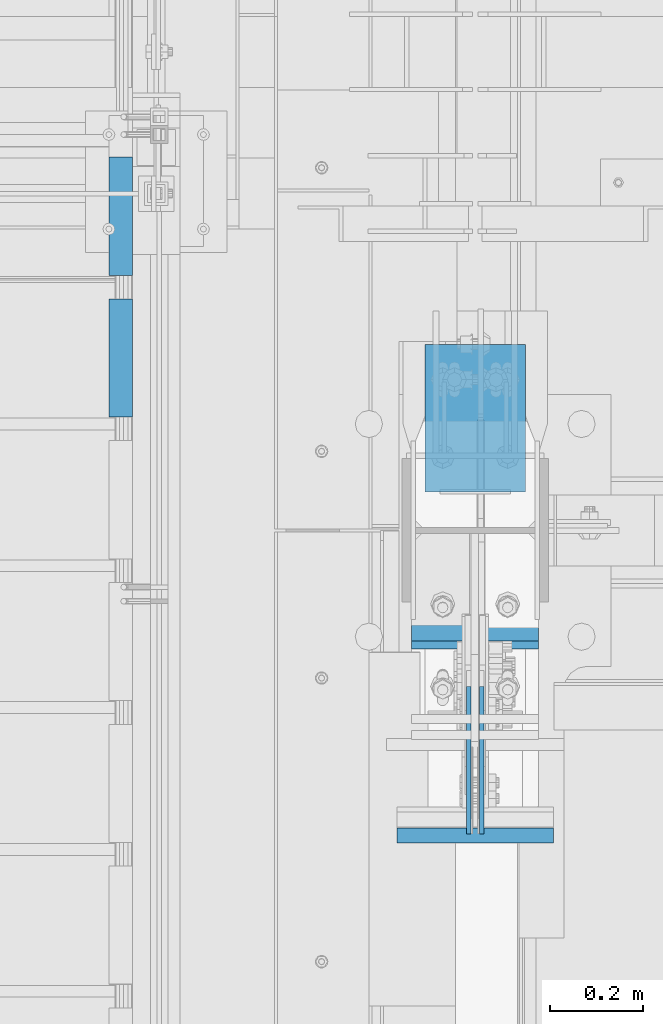
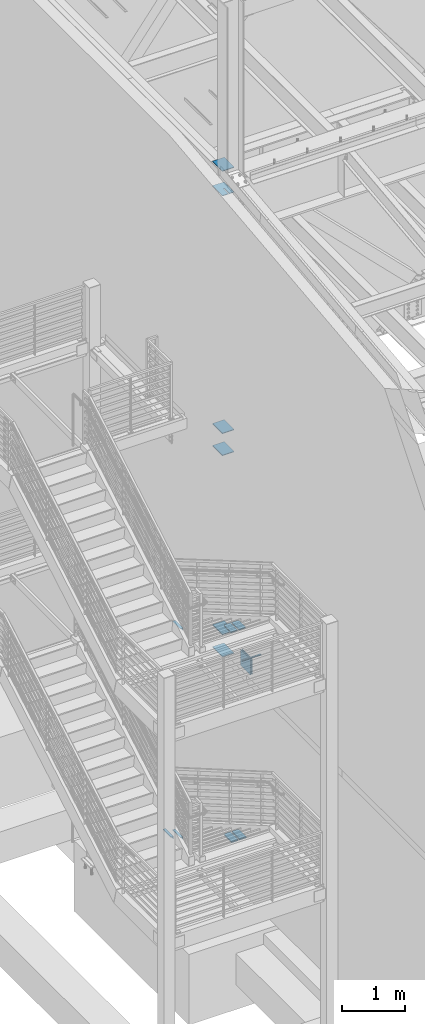
# One storey, part 871 of 1179: 16 beams, 10 elements without a shape of their own.
"""IFC2X3 building model written with IfcOpenShell, lengths in millimetres."""

from ifc_helpers import new_model, si_unit, frame, origin_with_axes, place, context, subcontext, project, spatial, faceted_brep, material, type_object, element, aggregate, save


model = new_model("IFC2X3")

# Units and contexts
model_context = context("Model", 3, precision=1e-05, world=origin_with_axes())
body_context = subcontext(model_context, "Body", "Model", "MODEL_VIEW")
ifc_project = project(units=[si_unit("LENGTHUNIT", "METRE", prefix="MILLI"), si_unit("AREAUNIT", "SQUARE_METRE"), si_unit("VOLUMEUNIT", "CUBIC_METRE"), si_unit("MASSUNIT", "GRAM", prefix="KILO"), si_unit("TIMEUNIT", "SECOND"), si_unit("PLANEANGLEUNIT", "RADIAN"), si_unit("SOLIDANGLEUNIT", "STERADIAN"), si_unit("THERMODYNAMICTEMPERATUREUNIT", "DEGREE_CELSIUS"), si_unit("LUMINOUSINTENSITYUNIT", "LUMEN")], contexts=[model_context])

# Site, building, storey
site_placement = place(None, origin_with_axes())
site = spatial("IfcSite", under=ifc_project, at=site_placement, CompositionType="ELEMENT")
building_placement = place(site_placement, origin_with_axes())
building = spatial("IfcBuilding", under=site, at=building_placement, Name="Undefined", CompositionType="ELEMENT")
storey_placement = place(building_placement, origin_with_axes())
storey = spatial("IfcBuildingStorey", under=building, at=storey_placement, Name="Undefined", CompositionType="ELEMENT", Elevation=0.0)

# Assembly, beam
assembly_1_placement = place(storey_placement, origin_with_axes())
assembly_1 = element("IfcElementAssembly", 1, at=assembly_1_placement, inside=storey, Name="STRINGER", AssemblyPlace="NOTDEFINED", PredefinedType="RIGID_FRAME")
ifc_material_1 = material(Name="STEEL/A36")
beam_type_1 = type_object("IfcBeamType", Name="L2X2X3/16", PredefinedType="NOTDEFINED")
beam_1_placement = place(assembly_1_placement, frame((-330.199999997209, 34889.1356222336, 4333.87499890225), z_axis=(-1.0, 0.0, 0.0), x_axis=(0.0, -1.0, 0.0)))
beam_1 = element("IfcBeam", 2, at=beam_1_placement, type_object=beam_type_1, material=ifc_material_1, Name="ANGLE", ObjectType="L2X2X3/16", context=body_context, shape_type="Brep", body=[
    faceted_brep([(0.0, 25.3999999999996, -25.4000000000015), (0.0, 25.3999999999996, 25.4000000000015), (254.0, 25.3999999999996, 25.4000000000001), (254.0, 25.3999999999996, -25.4000000000001), (0.0, 20.6374999999998, 25.4000000000015), (254.0, 20.6374999999998, 25.4000000000001), (0.0, 20.6374999999998, -20.6374999999971), (254.0, 20.6374999999998, -20.6374999999998), (0.0, -25.3999999999996, -20.6374999999971), (254.0, -25.3999999999996, -20.6374999999998), (0.0, -25.3999999999996, -25.4000000000015), (254.0, -25.3999999999996, -25.4000000000001)], [[[0, 1, 2, 3]], [[1, 4, 5, 2]], [[4, 6, 7, 5]], [[6, 8, 9, 7]], [[8, 10, 11, 9]], [[10, 0, 3, 11]], [[5, 7, 9, 11, 3, 2]], [[10, 8, 6, 4, 1, 0]]]),
])
aggregate(assembly_1, [beam_1])

# Assembly, beams
assembly_2_placement = place(storey_placement, origin_with_axes())
assembly_2 = element("IfcElementAssembly", 3, at=assembly_2_placement, inside=storey, Name="STRINGER", AssemblyPlace="NOTDEFINED", PredefinedType="RIGID_FRAME")
beam_2_placement = place(assembly_2_placement, frame((-330.200000005212, 34889.0824003931, 273.5839774682), z_axis=(-1.0, 0.0, 0.0), x_axis=(0.0, -1.0, 0.0)))
beam_2 = element("IfcBeam", 4, at=beam_2_placement, type_object=beam_type_1, material=ifc_material_1, Name="ANGLE", ObjectType="L2X2X3/16", context=body_context, shape_type="Brep", body=[
    faceted_brep([(0.0, 25.3999999999996, -25.4000000000015), (0.0, 25.3999999999996, 25.4000000000015), (254.0, 25.3999999999996, 25.4000000000001), (254.0, 25.3999999999996, -25.4000000000001), (0.0, 20.6374999999998, 25.4000000000015), (254.0, 20.6374999999998, 25.4000000000001), (0.0, 20.6374999999998, -20.6374999999971), (254.0, 20.6374999999998, -20.6374999999998), (0.0, -25.3999999999996, -20.6374999999971), (254.0, -25.3999999999996, -20.6374999999998), (0.0, -25.3999999999996, -25.4000000000015), (254.0, -25.3999999999996, -25.4000000000001)], [[[0, 1, 2, 3]], [[1, 4, 5, 2]], [[4, 6, 7, 5]], [[6, 8, 9, 7]], [[8, 10, 11, 9]], [[10, 0, 3, 11]], [[5, 7, 9, 11, 3, 2]], [[10, 8, 6, 4, 1, 0]]]),
])
beam_3_placement = place(assembly_2_placement, frame((-330.200000005171, 35193.8825541272, 97.102083331058), z_axis=(-1.0, 0.0, 0.0), x_axis=(0.0, -1.0, 0.0)))
beam_3 = element("IfcBeam", 5, at=beam_3_placement, type_object=beam_type_1, material=ifc_material_1, Name="ANGLE", ObjectType="L2X2X3/16", context=body_context, shape_type="Brep", body=[
    faceted_brep([(0.0, 25.3999999999996, -25.4000000000015), (0.0, 25.3999999999996, 25.4000000000015), (254.0, 25.3999999999996, 25.4000000000001), (254.0, 25.3999999999996, -25.4000000000001), (0.0, 20.6374999999998, 25.4000000000015), (254.0, 20.6374999999998, 25.4000000000001), (0.0, 20.6374999999998, -20.6374999999971), (254.0, 20.6374999999998, -20.6374999999998), (0.0, -25.3999999999996, -20.6374999999971), (254.0, -25.3999999999996, -20.6374999999998), (0.0, -25.3999999999996, -25.4000000000015), (254.0, -25.3999999999996, -25.4000000000001)], [[[0, 1, 2, 3]], [[1, 4, 5, 2]], [[4, 6, 7, 5]], [[6, 8, 9, 7]], [[8, 10, 11, 9]], [[10, 0, 3, 11]], [[5, 7, 9, 11, 3, 2]], [[10, 8, 6, 4, 1, 0]]]),
])
aggregate(assembly_2, [beam_2, beam_3])

# Assembly, beam
assembly_3_placement = place(storey_placement, origin_with_axes())
assembly_3 = element("IfcElementAssembly", 6, at=assembly_3_placement, inside=storey, Name="BEAM", AssemblyPlace="NOTDEFINED", PredefinedType="RIGID_FRAME")
ifc_material_2 = material(Name="STEEL/A572-GR.50")
beam_type_2 = type_object("IfcBeamType", PredefinedType="NOTDEFINED")
beam_4_placement = place(assembly_3_placement, frame((431.800036620873, 33719.866998869, 4077.8905), z_axis=(-1.0, 0.0, 0.0), x_axis=(0.0, 1.0, 0.0)))
beam_4 = element("IfcBeam", 7, at=beam_4_placement, type_object=beam_type_2, material=ifc_material_2, Name="PLATE", context=body_context, shape_type="Brep", body=[
    faceted_brep([(0.0, 4.76249999999982, -168.275000000001), (0.0, 4.76250000000073, 168.275), (31.75, 4.76249999999982, 168.275000000001), (31.75, 4.76249999999982, -168.275000000001), (0.0, -4.76250000000073, 168.275), (31.75, -4.76249999999982, 168.275000000001), (0.0, -4.76249999999982, -168.275000000001), (31.75, -4.76249999999982, -168.275000000001)], [[[0, 1, 2, 3]], [[1, 4, 5, 2]], [[4, 6, 7, 5]], [[6, 0, 3, 7]], [[5, 7, 3, 2]], [[6, 4, 1, 0]]]),
])
aggregate(assembly_3, [beam_4])

assembly_4_placement = place(storey_placement, origin_with_axes())
assembly_4 = element("IfcElementAssembly", 8, at=assembly_4_placement, inside=storey, Name="PLATE", AssemblyPlace="NOTDEFINED", PredefinedType="RIGID_FRAME")
beam_type_3 = type_object("IfcBeamType", PredefinedType="NOTDEFINED")
beam_5_placement = place(assembly_4_placement, frame((505.619000000002, 34153.8677008004, 4353.49928057188), z_axis=(1.0, 0.0, 0.0), x_axis=(0.0, 1.0, 0.0)))
beam_5 = element("IfcBeam", 9, at=beam_5_placement, type_object=beam_type_3, material=ifc_material_2, Name="PLATE", context=body_context, shape_type="Brep", body=[
    faceted_brep([(231.382299186545, -9.52499999999964, 40.480999976727), (231.382299199606, 9.52499999999964, 40.480999976727), (209.157299199604, 9.52499999999964, 62.7065000000002), (209.157299199604, -9.52499999999964, 62.7065000000002), (6.18456397205591e-11, -9.52499999999964, -62.7065000000084), (0.0, -9.52499999999964, 62.7065000000002), (0.0, 9.52499999999964, 62.7065000000002), (6.18456397205591e-11, 9.52499999999964, -62.7065000000084), (231.382299199602, 9.52499999999964, -62.7065000000002), (231.382299199602, -9.52499999999964, -62.7065000000002)], [[[0, 1, 2, 3]], [[4, 5, 6, 7]], [[4, 7, 8, 9]], [[5, 4, 9, 0, 3]], [[6, 5, 3, 2]], [[8, 7, 6, 2, 1]], [[9, 8, 1, 0]]]),
])
aggregate(assembly_4, [beam_5])

assembly_5_placement = place(storey_placement, origin_with_axes())
assembly_5 = element("IfcElementAssembly", 10, at=assembly_5_placement, inside=storey, Name="PLATE", AssemblyPlace="NOTDEFINED", PredefinedType="RIGID_FRAME")
beam_6_placement = place(assembly_5_placement, frame((357.981000000002, 34153.8677008004, 4353.49928057188), z_axis=(-1.0, 0.0, 0.0), x_axis=(0.0, 1.0, 0.0)))
beam_6 = element("IfcBeam", 11, at=beam_6_placement, type_object=beam_type_3, material=ifc_material_2, Name="PLATE", context=body_context, shape_type="Brep", body=[
    faceted_brep([(231.382299186545, -9.52499999999964, 40.480999976727), (231.382299199606, 9.52499999999964, 40.480999976727), (209.157299199604, 9.52499999999964, 62.7065000000002), (209.157299199604, -9.52499999999964, 62.7065000000002), (6.18456397205591e-11, -9.52499999999964, -62.7065000000084), (0.0, -9.52499999999964, 62.7065000000002), (0.0, 9.52499999999964, 62.7065000000002), (6.18456397205591e-11, 9.52499999999964, -62.7065000000084), (231.382299199602, 9.52499999999964, -62.7065000000002), (231.382299199602, -9.52499999999964, -62.7065000000002)], [[[0, 1, 2, 3]], [[4, 5, 6, 7]], [[4, 7, 8, 9]], [[5, 4, 9, 0, 3]], [[6, 5, 3, 2]], [[8, 7, 6, 2, 1]], [[9, 8, 1, 0]]]),
])
aggregate(assembly_5, [beam_6])

# Assembly, beams
assembly_6_placement = place(storey_placement, origin_with_axes())
assembly_6 = element("IfcElementAssembly", 12, at=assembly_6_placement, inside=storey, Name="COLUMN", AssemblyPlace="NOTDEFINED", PredefinedType="RIGID_FRAME")
beam_type_4 = type_object("IfcBeamType", PredefinedType="NOTDEFINED")
beam_7_placement = place(assembly_6_placement, frame((431.799999999996, 34474.1499999871, 12646.024999977), z_axis=(1.0, 0.0, 0.0), x_axis=(0.0, 1.0, 0.0)))
beam_7 = element("IfcBeam", 13, at=beam_7_placement, type_object=beam_type_4, material=ifc_material_2, Name="PLATE", context=body_context, shape_type="Brep", body=[
    faceted_brep([(0.0, -6.35000000000036, 19.8437500550863), (0.0, 6.35000000000036, 19.8437500550863), (150.812499998719, 6.35000000000036, 19.8437500546802), (150.812499998719, -6.35000000000036, 19.8437500546802), (153.850049742483, 6.35000000000036, 19.2395438442423), (153.850049742483, -6.35000000000036, 19.2395438442423), (156.425160073413, 6.35000000000036, 17.5189101313016), (156.425160073413, -6.35000000000036, 17.5189101313016), (158.145793787233, 6.35000000000036, 14.9437998009562), (158.145793787233, -6.35000000000036, 14.9437998009562), (150.812499998683, -6.35000000000036, 3.96875005468019), (150.812499998683, 6.35000000000036, 3.96875005468019), (0.0, 6.35000000000036, 3.96875005508628), (0.0, -6.35000000000036, 3.96875005508628), (153.850049743713, -6.35000000000036, 4.57295626562569), (153.850049743713, 6.35000000000036, 4.57295626562569), (156.42516007532, -6.35000000000036, 6.29358997996519), (156.42516007532, 6.35000000000036, 6.29358997996519), (158.14579378879, -6.35000000000036, 8.8687003121604), (158.14579378879, 6.35000000000036, 8.8687003121604), (158.749999998705, -6.35000000000036, 11.9062500573978), (158.749999998705, 6.35000000000036, 11.9062500573978), (0.0, 6.35000000000036, 107.949999999997), (0.0, -6.35000000000036, 107.949999999997), (317.5, -6.35000000000036, 107.949999999997), (317.5, 6.35000000000036, 107.949999999997), (317.5, -6.35000000000036, -107.949999999997), (317.5, 6.35000000000036, -107.949999999997), (0.0, -6.35000000000036, -107.949999999997), (0.0, 6.35000000000036, -107.949999999997)], [[[0, 1, 2, 3]], [[3, 2, 4, 5]], [[5, 4, 6, 7]], [[7, 6, 8, 9]], [[10, 11, 12, 13]], [[14, 15, 11, 10]], [[16, 17, 15, 14]], [[18, 19, 17, 16]], [[20, 21, 19, 18]], [[9, 8, 21, 20]], [[22, 23, 24, 25]], [[24, 26, 27, 25]], [[28, 29, 27, 26]], [[29, 28, 13, 12]], [[6, 4, 2, 1, 22, 25, 27, 29, 12, 11, 15, 17, 19, 21, 8]], [[23, 22, 1, 0]], [[16, 14, 10, 13, 28, 26, 24, 23, 0, 3, 5, 7, 9, 20, 18]]]),
])
beam_8_placement = place(assembly_6_placement, frame((431.800000009011, 34474.15, 13125.4499999541), z_axis=(1.0, 0.0, 0.0), x_axis=(0.0, 1.0, 0.0)))
beam_8 = element("IfcBeam", 14, at=beam_8_placement, type_object=beam_type_4, material=ifc_material_2, Name="PLATE", context=body_context, shape_type="Brep", body=[
    faceted_brep([(0.0, 6.35000000000036, -107.949999999997), (0.0, 6.35000000000036, 107.949999999997), (317.5, 6.35000000000036, 107.949999999997), (317.5, 6.35000000000036, -107.949999999997), (0.0, -6.35000000000036, 107.949999999997), (317.5, -6.35000000000036, 107.949999999997), (0.0, -6.35000000000036, -107.949999999997), (317.5, -6.35000000000036, -107.949999999997)], [[[0, 1, 2, 3]], [[1, 4, 5, 2]], [[4, 6, 7, 5]], [[6, 0, 3, 7]], [[5, 7, 3, 2]], [[6, 4, 1, 0]]]),
])
beam_9_placement = place(assembly_6_placement, frame((431.799999999996, 34474.15, 7591.425), z_axis=(1.0, 0.0, 0.0), x_axis=(0.0, 1.0, 0.0)))
beam_9 = element("IfcBeam", 15, at=beam_9_placement, type_object=beam_type_4, material=ifc_material_2, Name="PLATE", context=body_context, shape_type="Brep", body=[
    faceted_brep([(0.0, 6.35000000000036, -107.949999999997), (0.0, 6.35000000000036, 107.949999999997), (317.5, 6.35000000000036, 107.949999999997), (317.5, 6.35000000000036, -107.949999999997), (0.0, -6.35000000000036, 107.949999999997), (317.5, -6.35000000000036, 107.949999999997), (0.0, -6.35000000000036, -107.949999999997), (317.5, -6.35000000000036, -107.949999999997)], [[[0, 1, 2, 3]], [[1, 4, 5, 2]], [[4, 6, 7, 5]], [[6, 0, 3, 7]], [[5, 7, 3, 2]], [[6, 4, 1, 0]]]),
])
beam_10_placement = place(assembly_6_placement, frame((431.799999999996, 34474.15, 8020.05), z_axis=(1.0, 0.0, 0.0), x_axis=(0.0, 1.0, 0.0)))
beam_10 = element("IfcBeam", 16, at=beam_10_placement, type_object=beam_type_4, material=ifc_material_2, Name="PLATE", context=body_context, shape_type="Brep", body=[
    faceted_brep([(0.0, 6.35000000000036, -107.949999999997), (0.0, 6.35000000000036, 107.949999999997), (317.5, 6.35000000000036, 107.949999999997), (317.5, 6.35000000000036, -107.949999999997), (0.0, -6.35000000000036, 107.949999999997), (317.5, -6.35000000000036, 107.949999999997), (0.0, -6.35000000000036, -107.949999999997), (317.5, -6.35000000000036, -107.949999999997)], [[[0, 1, 2, 3]], [[1, 4, 5, 2]], [[4, 6, 7, 5]], [[6, 0, 3, 7]], [[5, 7, 3, 2]], [[6, 4, 1, 0]]]),
])
beam_11_placement = place(assembly_6_placement, frame((431.799999999999, 34474.15, 3676.65), z_axis=(1.0, 0.0, 0.0), x_axis=(0.0, 1.0, 0.0)))
beam_11 = element("IfcBeam", 17, at=beam_11_placement, type_object=beam_type_4, material=ifc_material_2, Name="PLATE", context=body_context, shape_type="Brep", body=[
    faceted_brep([(0.0, 6.35000000000036, -107.949999999997), (0.0, 6.35000000000036, 107.949999999997), (317.5, 6.35000000000036, 107.949999999997), (317.5, 6.35000000000036, -107.949999999997), (0.0, -6.35000000000036, 107.949999999997), (317.5, -6.35000000000036, 107.949999999997), (0.0, -6.35000000000036, -107.949999999997), (317.5, -6.35000000000036, -107.949999999997)], [[[0, 1, 2, 3]], [[1, 4, 5, 2]], [[4, 6, 7, 5]], [[6, 0, 3, 7]], [[5, 7, 3, 2]], [[6, 4, 1, 0]]]),
])
beam_12_placement = place(assembly_6_placement, frame((431.799999999999, 34474.15, 4108.45), z_axis=(1.0, 0.0, 0.0), x_axis=(0.0, 1.0, 0.0)))
beam_12 = element("IfcBeam", 18, at=beam_12_placement, type_object=beam_type_4, material=ifc_material_2, Name="PLATE", context=body_context, shape_type="Brep", body=[
    faceted_brep([(0.0, 6.35000000000036, -107.949999999997), (0.0, 6.35000000000036, 107.949999999997), (317.5, 6.35000000000036, 107.949999999997), (317.5, 6.35000000000036, -107.949999999997), (0.0, -6.35000000000036, 107.949999999997), (317.5, -6.35000000000036, 107.949999999997), (0.0, -6.35000000000036, -107.949999999997), (317.5, -6.35000000000036, -107.949999999997)], [[[0, 1, 2, 3]], [[1, 4, 5, 2]], [[4, 6, 7, 5]], [[6, 0, 3, 7]], [[5, 7, 3, 2]], [[6, 4, 1, 0]]]),
])
aggregate(assembly_6, [beam_7, beam_8, beam_9, beam_10, beam_11, beam_12])

# Assembly, beam
assembly_7_placement = place(storey_placement, origin_with_axes())
assembly_7 = element("IfcElementAssembly", 19, at=assembly_7_placement, inside=storey, Name="PLATE", AssemblyPlace="NOTDEFINED", PredefinedType="RIGID_FRAME")
beam_type_5 = type_object("IfcBeamType", PredefinedType="NOTDEFINED")
beam_13_placement = place(assembly_7_placement, frame((356.393499999997, 34136.630498769, 285.099398203347), z_axis=(-1.0, 0.0, 0.0), x_axis=(0.0, 1.0, 0.0)))
beam_13 = element("IfcBeam", 20, at=beam_13_placement, type_object=beam_type_5, material=ifc_material_2, Name="PLATE", context=body_context, shape_type="Brep", body=[
    faceted_brep([(248.619501230954, 12.7, 38.894), (226.394501230956, 12.7, 61.119), (226.394501230956, -12.7, 61.119), (248.619501230954, -12.7, 38.894), (248.619501230954, 12.7, -61.119), (0.0, 12.7, -61.1189999999988), (0.0, 12.7, 61.1189999999988), (0.0, -12.7, 61.1189999999988), (0.0, -12.7, -61.1189999999988), (248.619501230954, -12.7, -61.119)], [[[0, 1, 2, 3]], [[4, 5, 6, 1, 0]], [[6, 7, 2, 1]], [[7, 8, 9, 3, 2]], [[8, 5, 4, 9]], [[9, 4, 0, 3]], [[8, 7, 6, 5]]]),
])
aggregate(assembly_7, [beam_13])

assembly_8_placement = place(storey_placement, origin_with_axes())
assembly_8 = element("IfcElementAssembly", 21, at=assembly_8_placement, inside=storey, Name="PLATE", AssemblyPlace="NOTDEFINED", PredefinedType="RIGID_FRAME")
beam_14_placement = place(assembly_8_placement, frame((507.206500000001, 34136.630498769, 285.099398203347), z_axis=(1.0, 0.0, 0.0), x_axis=(0.0, 1.0, 0.0)))
beam_14 = element("IfcBeam", 22, at=beam_14_placement, type_object=beam_type_5, material=ifc_material_2, Name="PLATE", context=body_context, shape_type="Brep", body=[
    faceted_brep([(248.619501230954, 12.7, 38.894), (226.394501230956, 12.7, 61.119), (226.394501230956, -12.7, 61.119), (248.619501230954, -12.7, 38.894), (248.619501230954, 12.7, -61.119), (0.0, 12.7, -61.1189999999988), (0.0, 12.7, 61.1189999999988), (0.0, -12.7, 61.1189999999988), (0.0, -12.7, -61.1189999999988), (248.619501230954, -12.7, -61.119)], [[[0, 1, 2, 3]], [[4, 5, 6, 1, 0]], [[6, 7, 2, 1]], [[7, 8, 9, 3, 2]], [[8, 5, 4, 9]], [[9, 4, 0, 3]], [[8, 7, 6, 5]]]),
])
aggregate(assembly_8, [beam_14])

assembly_9_placement = place(storey_placement, origin_with_axes())
assembly_9 = element("IfcElementAssembly", 23, at=assembly_9_placement, inside=storey, Name="PLATE", AssemblyPlace="NOTDEFINED", PredefinedType="RIGID_FRAME")
beam_type_6 = type_object("IfcBeamType", PredefinedType="NOTDEFINED")
beam_15_placement = place(assembly_9_placement, frame((417.512500000002, 33738.916998869, 3892.55), z_axis=(0.0, 0.0, -1.0), x_axis=(0.0, 1.0, 0.0)))
beam_15 = element("IfcBeam", 24, at=beam_15_placement, type_object=beam_type_6, material=ifc_material_2, Name="PLATE", context=body_context, shape_type="Brep", body=[
    faceted_brep([(0.0, 4.76250000000073, -152.4), (0.0, 4.76250000000073, 152.4), (317.5, 4.76250000000073, 152.4), (317.5, 4.76250000000073, -152.4), (0.0, -4.76250000000073, 152.4), (317.5, -4.76250000000073, 152.4), (0.0, -4.76250000000073, -152.4), (317.5, -4.76250000000073, -152.4)], [[[0, 1, 2, 3]], [[1, 4, 5, 2]], [[4, 6, 7, 5]], [[6, 0, 3, 7]], [[5, 7, 3, 2]], [[6, 4, 1, 0]]]),
])
aggregate(assembly_9, [beam_15])

assembly_10_placement = place(storey_placement, origin_with_axes())
assembly_10 = element("IfcElementAssembly", 25, at=assembly_10_placement, inside=storey, Name="PLATE", AssemblyPlace="NOTDEFINED", PredefinedType="RIGID_FRAME")
beam_16_placement = place(assembly_10_placement, frame((446.087213611823, 34056.416998869, 3892.55), z_axis=(0.0, 0.0, -1.0), x_axis=(0.0, -1.0, 0.0)))
beam_16 = element("IfcBeam", 26, at=beam_16_placement, type_object=beam_type_6, material=ifc_material_2, Name="PLATE", context=body_context, shape_type="Brep", body=[
    faceted_brep([(0.0, 4.76250000000073, -152.4), (0.0, 4.76250000000073, 152.4), (317.5, 4.76250000000073, 152.4), (317.5, 4.76250000000073, -152.4), (0.0, -4.76250000000073, 152.4), (317.5, -4.76250000000073, 152.4), (0.0, -4.76250000000073, -152.4), (317.5, -4.76250000000073, -152.4)], [[[0, 1, 2, 3]], [[1, 4, 5, 2]], [[4, 6, 7, 5]], [[6, 0, 3, 7]], [[5, 7, 3, 2]], [[6, 4, 1, 0]]]),
])
aggregate(assembly_10, [beam_16])

save(model, "model.ifc")
